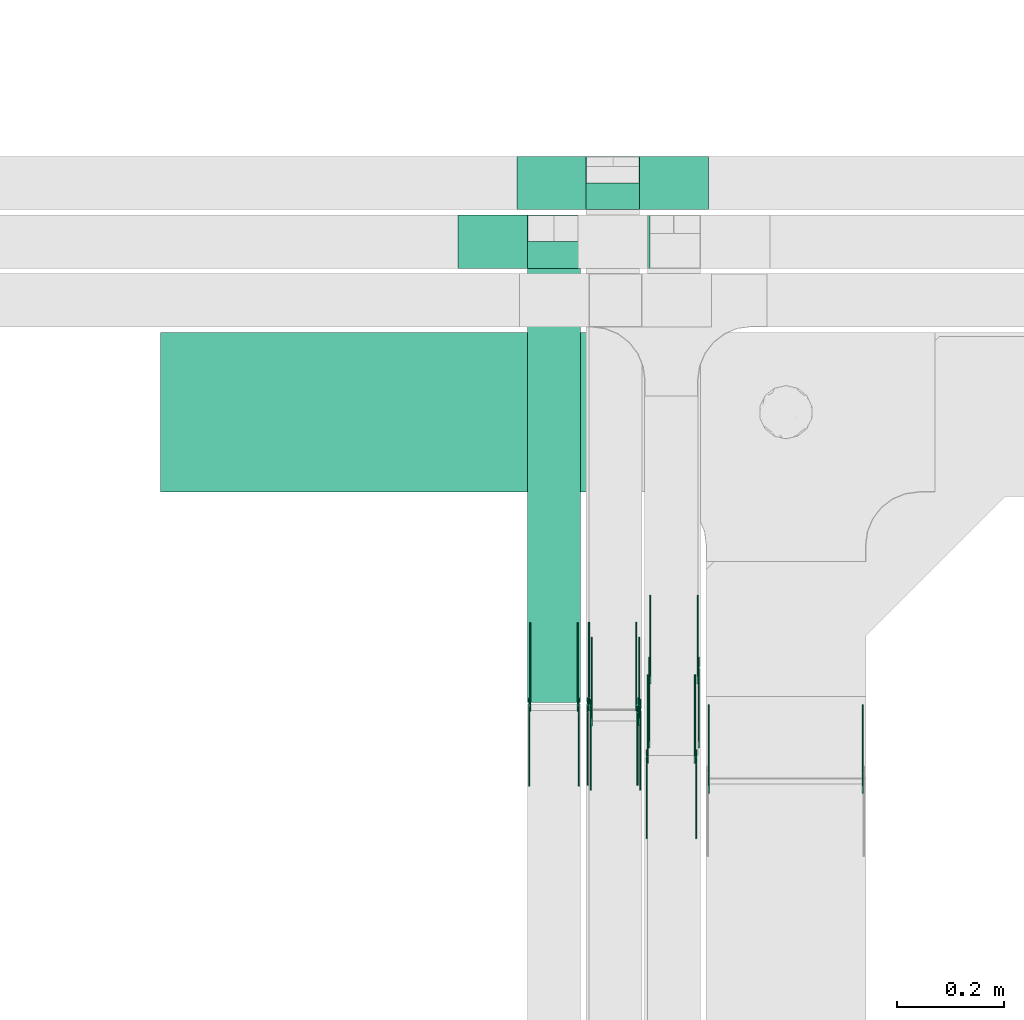
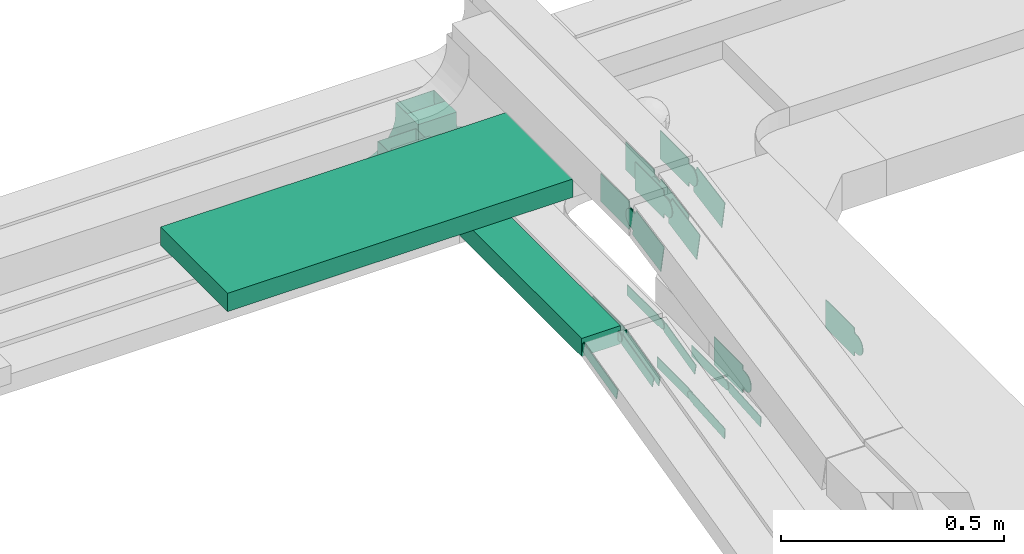
# One storey, part 9 of 33: 24 flow fittings, 2 flow segments.
"""IFC2X3 building model written with IfcOpenShell, lengths in millimetres."""

import ifcopenshell
import ifcopenshell.guid

model = None  # the IFC model being written
_history = None  # IfcOwnerHistory: only IFC2X3 demands one
_inside = {}  # id of a spatial element -> (the spatial element, [elements in it])
_under = {}  # id of a project, library or spatial element -> (it, [spatial elements below it])
_declared = {}  # id of a project -> (the project, [libraries it declares])
_typed = {}  # id of a type object -> (the type object, [elements of that type])
_made_of = {}  # id of a material, layer set ... -> (it, [elements and type objects made of it])


def new_model(schema):
    """Start an empty IFC model of exactly this schema.

    Asked for "IFC4X3", IfcOpenShell would pick the latest addendum, in which some entities
    have other attributes; the version numbers below select the first issue.
    IFC2X3 requires an IfcOwnerHistory on every rooted entity: one is made here for all.
    """
    global model, _history
    if schema == "IFC4X3":
        model = ifcopenshell.file(schema_version=(4, 3, 0, 0))
    else:
        model = ifcopenshell.file(schema=schema)
    _inside.clear()
    _under.clear()
    _declared.clear()
    _typed.clear()
    _made_of.clear()
    _history = None
    if model.schema == "IFC2X3":
        org = make("IfcOrganization", Name="unknown")
        user = make(
            "IfcPersonAndOrganization",
            ThePerson=make("IfcPerson", FamilyName="unknown"),
            TheOrganization=org,
        )
        app = make(
            "IfcApplication",
            ApplicationDeveloper=org,
            Version="unknown",
            ApplicationFullName="unknown",
            ApplicationIdentifier="unknown",
        )
        _history = make(
            "IfcOwnerHistory",
            OwningUser=user,
            OwningApplication=app,
            ChangeAction="ADDED",
            CreationDate=0,
        )
    return model


def make(cls, **values):
    """One entity of the class cls with the attributes given. An attribute that is None is left unset."""
    return model.create_entity(
        cls, **{name: value for name, value in values.items() if value is not None}
    )


def entity(cls, *values):
    """Any entity or typed value of the class cls, its attributes in the order of the schema. None: left unset."""
    e = model.create_entity(cls)
    for i, value in enumerate(values):
        if value is not None:
            e[i] = value
    return e


def rooted(cls, **values):
    """An entity with a GlobalId (a new one), such as an element, a storey or a relation."""
    return make(cls, GlobalId=ifcopenshell.guid.new(), OwnerHistory=_history, **values)


def si_unit(unit_type, name, prefix=None):
    """IfcSIUnit, for example si_unit("LENGTHUNIT", "METRE", prefix="MILLI")."""
    return make("IfcSIUnit", UnitType=unit_type, Prefix=prefix, Name=name)


def converted_unit(unit_type, name, factor, base, dimensions=None, offset=None):
    """IfcConversionBasedUnit, such as the inch: factor (a typed value) times the base unit."""
    return make(
        "IfcConversionBasedUnit"
        if offset is None
        else "IfcConversionBasedUnitWithOffset",
        ConversionOffset=offset,
        Dimensions=None
        if dimensions is None
        else entity("IfcDimensionalExponents", *dimensions),
        UnitType=unit_type,
        Name=name,
        ConversionFactor=make(
            "IfcMeasureWithUnit", ValueComponent=factor, UnitComponent=base
        ),
    )


def derived_unit(unit_type, elements):
    """IfcDerivedUnit: a product of units, each with its exponent."""
    return make(
        "IfcDerivedUnit",
        Elements=[
            make("IfcDerivedUnitElement", Unit=unit, Exponent=power)
            for unit, power in elements
        ],
        UnitType=unit_type,
    )


def assignment(units):
    """IfcUnitAssignment: the units of a project."""
    return None if units is None else make("IfcUnitAssignment", Units=units)


def point(xyz):
    """IfcCartesianPoint."""
    return None if xyz is None else make("IfcCartesianPoint", Coordinates=xyz)


def direction(xyz):
    """IfcDirection."""
    return None if xyz is None else make("IfcDirection", DirectionRatios=xyz)


def frame(location, z_axis=None, x_axis=None):
    """IfcAxis2Placement3D, a coordinate frame: its origin and axes. An axis left out is left unset."""
    return make(
        "IfcAxis2Placement3D",
        Location=point(location),
        Axis=direction(z_axis),
        RefDirection=direction(x_axis),
    )


def frame_2d(location, x_axis=None):
    """IfcAxis2Placement2D, a coordinate frame in the plane: its origin and x axis."""
    return make(
        "IfcAxis2Placement2D", Location=point(location), RefDirection=direction(x_axis)
    )


def origin():
    """The frame at (0, 0, 0) with its axes left unset."""
    return frame((0.0, 0.0, 0.0))


def origin_2d_with_axis():
    """The frame at (0, 0) in the plane with the x axis (1, 0) written out."""
    return frame_2d((0.0, 0.0), x_axis=(1.0, 0.0))


def place(relative_to, where):
    """IfcLocalPlacement: puts the frame where relative to a parent placement (None: the world)."""
    return make(
        "IfcLocalPlacement", PlacementRelTo=relative_to, RelativePlacement=where
    )


def context(
    kind, dimensions, precision=None, world=None, true_north=None, identifier=None
):
    """IfcGeometricRepresentationContext, for example the 3D "Model" context."""
    return make(
        "IfcGeometricRepresentationContext",
        ContextIdentifier=identifier,
        ContextType=kind,
        CoordinateSpaceDimension=dimensions,
        Precision=precision,
        WorldCoordinateSystem=world,
        TrueNorth=true_north,
    )


def subcontext(parent, identifier, kind, view, scale=None):
    """IfcGeometricRepresentationSubContext, for example "Body" below "Model"."""
    return make(
        "IfcGeometricRepresentationSubContext",
        ContextIdentifier=identifier,
        ContextType=kind,
        ParentContext=parent,
        TargetScale=scale,
        TargetView=view,
    )


def project(units=None, contexts=None):
    """IfcProject with its units and contexts."""
    return rooted(
        "IfcProject",
        Name="project",
        RepresentationContexts=contexts,
        UnitsInContext=assignment(units),
    )


def spatial(cls, under=None, at=None, **own):
    """A site, building, storey or space (cls), placed at a placement, below another one or the project."""
    s = rooted(cls, ObjectPlacement=at, **own)
    if under is not None:
        _under.setdefault(under.id(), (under, []))[1].append(s)
    return s


def polyline(points):
    """IfcPolyline through the points."""
    return make("IfcPolyline", Points=[point(p) for p in points])


def circle_curve(where, radius):
    """IfcCircle in the frame where."""
    return make("IfcCircle", Position=where, Radius=radius)


def parameter(value):
    """IfcParameterValue: where a trimmed curve begins or ends, as a parameter of its basis curve."""
    return model.create_entity("IfcParameterValue", value)


def trimmed(basis, trim1, trim2, sense, master):
    """IfcTrimmedCurve: the piece of a basis curve between two trims."""
    return make(
        "IfcTrimmedCurve",
        BasisCurve=basis,
        Trim1=trim1,
        Trim2=trim2,
        SenseAgreement=sense,
        MasterRepresentation=master,
    )


def segment(curve, same_sense, transition):
    """IfcCompositeCurveSegment."""
    return make(
        "IfcCompositeCurveSegment",
        Transition=transition,
        SameSense=same_sense,
        ParentCurve=curve,
    )


def composite_curve(segments, self_intersect=None):
    """IfcCompositeCurve: segments joined end to end."""
    return make("IfcCompositeCurve", Segments=segments, SelfIntersect=self_intersect)


def profile(cls, at=None, kind="AREA", **sizes):
    """A parametric profile (cls). Its sizes go by their IFC names, for example OverallWidth=200.0."""
    return make(cls, ProfileType=kind, Position=at, **sizes)


def rectangle(**sizes):
    """IfcRectangleProfileDef."""
    return profile("IfcRectangleProfileDef", **sizes)


def outline(outer, holes=None, kind="AREA"):
    """IfcArbitraryClosedProfileDef: a profile drawn as a closed curve; with holes, ...WithVoids."""
    if holes is None:
        return make("IfcArbitraryClosedProfileDef", ProfileType=kind, OuterCurve=outer)
    return make(
        "IfcArbitraryProfileDefWithVoids",
        ProfileType=kind,
        OuterCurve=outer,
        InnerCurves=holes,
    )


def extrude(swept, where, along, depth):
    """IfcExtrudedAreaSolid: the profile swept, set in the frame where, extruded along a direction by depth."""
    return make(
        "IfcExtrudedAreaSolid",
        SweptArea=swept,
        Position=where,
        ExtrudedDirection=direction(along),
        Depth=depth,
    )


def shape(context_of_items, identifier, shape_type, items):
    """IfcShapeRepresentation: the items that make up one representation, for example the "Body"."""
    return make(
        "IfcShapeRepresentation",
        ContextOfItems=context_of_items,
        RepresentationIdentifier=identifier,
        RepresentationType=shape_type,
        Items=items,
    )


def source(mapping_origin, context_of_items, identifier, shape_type, items):
    """IfcRepresentationMap: a shape defined once, which mapped items show again and again."""
    return make(
        "IfcRepresentationMap",
        MappingOrigin=mapping_origin,
        MappedRepresentation=shape(context_of_items, identifier, shape_type, items),
    )


def transform(
    local_origin,
    x_axis=None,
    y_axis=None,
    z_axis=None,
    scale=None,
    scale2=None,
    scale3=None,
    uniform=True,
):
    """IfcCartesianTransformationOperator3D, or its non-uniform kind. x_axis, y_axis, z_axis: its Axis1, 2, 3."""
    if uniform:
        return make(
            "IfcCartesianTransformationOperator3D",
            Axis1=direction(x_axis),
            Axis2=direction(y_axis),
            LocalOrigin=point(local_origin),
            Scale=scale,
            Axis3=direction(z_axis),
        )
    return make(
        "IfcCartesianTransformationOperator3DnonUniform",
        Axis1=direction(x_axis),
        Axis2=direction(y_axis),
        LocalOrigin=point(local_origin),
        Scale=scale,
        Axis3=direction(z_axis),
        Scale2=scale2,
        Scale3=scale3,
    )


def mapped(mapping_source, mapping_target):
    """IfcMappedItem: shows the shape of a source again, moved by a transform."""
    return make(
        "IfcMappedItem", MappingSource=mapping_source, MappingTarget=mapping_target
    )


def material(Name=None, Category=None):
    """IfcMaterial."""
    return make("IfcMaterial", Name=Name, Category=Category)


def material_list(materials):
    """IfcMaterialList."""
    return make("IfcMaterialList", Materials=materials)


def made_of(thing, what):
    """Note that an element or type object is made of a material, layer set ...; save() writes the relation."""
    if what is not None:
        _made_of.setdefault(what.id(), (what, []))[1].append(thing)
    return thing


def type_object(cls, material=None, **own):
    """A type object (cls), such as IfcWallType, which elements share."""
    return made_of(rooted(cls, **own), material)


def type_shapes(of_type, sources):
    """Give a type object the sources (RepresentationMaps) that its elements show as mapped items."""
    of_type.RepresentationMaps = sources


def element(
    cls,
    number,
    at=None,
    inside=None,
    cuts=None,
    type_object=None,
    material=None,
    context=None,
    identifier="Body",
    shape_type=None,
    held_by="IfcProductDefinitionShape",
    body=None,
    shapes=None,
    **own,
):
    """One element of the class cls, such as IfcWall. Its Tag is "e" and its number.

    at: its placement. inside: the storey or other place that contains it. cuts: it is an
    opening in that element (IfcRelVoidsElement). A single representation is given by context,
    identifier, shape_type and body (its items); several are given by shapes. held_by: the class
    of the entity that holds the representations. save() writes the other relations.
    """
    e = rooted(cls, Tag="e%d" % number, ObjectPlacement=at, **own)
    if body is not None:
        shapes = [shape(context, identifier, shape_type, body)]
    if shapes is not None:
        e.Representation = make(held_by, Representations=shapes)
    if inside is not None:
        _inside.setdefault(inside.id(), (inside, []))[1].append(e)
    if cuts is not None:
        rooted(
            "IfcRelVoidsElement", RelatingBuildingElement=cuts, RelatedOpeningElement=e
        )
    if type_object is not None:
        _typed.setdefault(type_object.id(), (type_object, []))[1].append(e)
    return made_of(e, material)


def aggregate(whole, parts):
    """IfcRelAggregates: a whole, such as a stair, and the parts it consists of."""
    return rooted("IfcRelAggregates", RelatingObject=whole, RelatedObjects=parts)


def save(model, path):
    """Write the relations noted so far, then the file.

    IfcRelAggregates (storeys below a building ...), IfcRelContainedInSpatialStructure (elements
    in a storey), IfcRelDefinesByType, IfcRelAssociatesMaterial and IfcRelDeclares: one each for
    every whole, place, type object, material and project.
    """
    for whole, parts in _under.values():
        aggregate(whole, parts)
    for where, things in _inside.values():
        rooted(
            "IfcRelContainedInSpatialStructure",
            RelatedElements=things,
            RelatingStructure=where,
        )
    for kind, things in _typed.values():
        rooted("IfcRelDefinesByType", RelatedObjects=things, RelatingType=kind)
    for what, things in _made_of.values():
        rooted("IfcRelAssociatesMaterial", RelatedObjects=things, RelatingMaterial=what)
    for by, libraries in _declared.values():
        rooted("IfcRelDeclares", RelatingContext=by, RelatedDefinitions=libraries)
    model.write(path)


model = new_model("IFC2X3")

# Units and contexts
model_context = context("Model", 3, precision=0.01, world=origin(), true_north=direction((6.12303176911189e-17, 1.0)))
body_context = subcontext(model_context, "Body", "Model", "MODEL_VIEW")
ifc_project = project(units=[si_unit("LENGTHUNIT", "METRE", prefix="MILLI"), si_unit("AREAUNIT", "SQUARE_METRE"), si_unit("VOLUMEUNIT", "CUBIC_METRE"), converted_unit("PLANEANGLEUNIT", "DEGREE", entity("IfcRatioMeasure", 0.0174532925199433), si_unit("PLANEANGLEUNIT", "RADIAN"), dimensions=[0, 0, 0, 0, 0, 0, 0]), si_unit("MASSUNIT", "GRAM", prefix="KILO"), derived_unit("MASSDENSITYUNIT", [(si_unit("MASSUNIT", "GRAM", prefix="KILO"), 1), (si_unit("LENGTHUNIT", "METRE"), -3)]), derived_unit("MOMENTOFINERTIAUNIT", [(si_unit("LENGTHUNIT", "METRE"), 4)]), si_unit("TIMEUNIT", "SECOND"), si_unit("FREQUENCYUNIT", "HERTZ"), si_unit("THERMODYNAMICTEMPERATUREUNIT", "DEGREE_CELSIUS"), derived_unit("THERMALTRANSMITTANCEUNIT", [(si_unit("MASSUNIT", "GRAM", prefix="KILO"), 1), (si_unit("THERMODYNAMICTEMPERATUREUNIT", "KELVIN"), -1), (si_unit("TIMEUNIT", "SECOND"), -3)]), derived_unit("VOLUMETRICFLOWRATEUNIT", [(si_unit("LENGTHUNIT", "METRE"), 3), (si_unit("TIMEUNIT", "SECOND"), -1)]), derived_unit("MASSFLOWRATEUNIT", [(si_unit("MASSUNIT", "GRAM", prefix="KILO"), 1), (si_unit("TIMEUNIT", "SECOND"), -1)]), derived_unit("ROTATIONALFREQUENCYUNIT", [(si_unit("TIMEUNIT", "SECOND"), -1)]), si_unit("ELECTRICCURRENTUNIT", "AMPERE"), si_unit("ELECTRICVOLTAGEUNIT", "VOLT"), si_unit("POWERUNIT", "WATT"), si_unit("FORCEUNIT", "NEWTON", prefix="KILO"), si_unit("ILLUMINANCEUNIT", "LUX"), si_unit("LUMINOUSFLUXUNIT", "LUMEN"), si_unit("LUMINOUSINTENSITYUNIT", "CANDELA"), derived_unit("USERDEFINED", [(si_unit("MASSUNIT", "GRAM", prefix="KILO"), -1), (si_unit("LENGTHUNIT", "METRE"), -2), (si_unit("TIMEUNIT", "SECOND"), 3), (si_unit("LUMINOUSFLUXUNIT", "LUMEN"), 1)]), derived_unit("LINEARVELOCITYUNIT", [(si_unit("LENGTHUNIT", "METRE"), 1), (si_unit("TIMEUNIT", "SECOND"), -1)]), si_unit("PRESSUREUNIT", "PASCAL"), derived_unit("USERDEFINED", [(si_unit("LENGTHUNIT", "METRE"), -2), (si_unit("MASSUNIT", "GRAM", prefix="KILO"), 1), (si_unit("TIMEUNIT", "SECOND"), -2)]), derived_unit("LINEARFORCEUNIT", [(si_unit("MASSUNIT", "GRAM", prefix="KILO"), 1), (si_unit("LENGTHUNIT", "METRE"), 1), (si_unit("TIMEUNIT", "SECOND"), -2), (si_unit("LENGTHUNIT", "METRE"), -1)]), derived_unit("PLANARFORCEUNIT", [(si_unit("MASSUNIT", "GRAM", prefix="KILO"), 1), (si_unit("LENGTHUNIT", "METRE"), 1), (si_unit("TIMEUNIT", "SECOND"), -2), (si_unit("LENGTHUNIT", "METRE"), -2)])], contexts=[model_context])

# Site, building, storey
site_placement = place(None, frame((0.0, -0.00077364408347762, 0.0)))
site = spatial("IfcSite", under=ifc_project, at=site_placement, CompositionType="ELEMENT")
building_placement = place(site_placement, origin())
building = spatial("IfcBuilding", under=site, at=building_placement, CompositionType="ELEMENT")
storey_placement = place(building_placement, frame((0.0, 0.0, 8100.0)))
storey = spatial("IfcBuildingStorey", under=building, at=storey_placement, CompositionType="ELEMENT", Elevation=8100.0)

# Flow segments
cable_carrier_segment_type = type_object("IfcCableCarrierSegmentType", PredefinedType="CABLETRAYSEGMENT")
flow_segment_1_placement = place(storey_placement, frame((17222.5, 14182.2782357464, 2840.01712441882)))
element("IfcFlowSegment", 1, at=flow_segment_1_placement, inside=storey, type_object=cable_carrier_segment_type, context=body_context, shape_type="SweptSolid", body=[
    extrude(rectangle(XDim=893.552364207236, YDim=300.000000000001, at=origin_2d_with_axis()), frame((446.776182103618, 150.0, 0.0), z_axis=(0.0, 0.0, 1.0), x_axis=(-1.0, 0.0, 0.0)), (0.0, 0.0, 1.0), 50.0000000000016),
])
flow_segment_2_placement = place(storey_placement, frame((17911.0123642174, 13787.7761473491, 2715.0)))
element("IfcFlowSegment", 2, at=flow_segment_2_placement, inside=storey, type_object=cable_carrier_segment_type, context=body_context, shape_type="SweptSolid", body=[
    extrude(rectangle(XDim=855.502088397182, YDim=99.9999999999989, at=frame_2d((1.10844666778576e-12, -1.08357767203415e-12), x_axis=(1.0, 0.0))), frame((50.0, 427.751044198592, 0.0), z_axis=(0.0, 0.0, 1.0), x_axis=(0.0, 1.0, 0.0)), (0.0, 0.0, 1.0), 50.0000000000016),
])

# Flow fittings
ifc_material_1 = material(Name="G")
cable_carrier_fitting_type_1 = type_object("IfcCableCarrierFittingType", PredefinedType="NOTDEFINED", material=ifc_material_1)
shared_shape_1 = source(origin(), body_context, "Body", "SweptSolid", [
    extrude(outline(composite_curve([segment(trimmed(circle_curve(frame_2d((-44.5901162790698, 0.0), x_axis=(1.0, 0.0)), 12.5), [parameter(90.0000000000007)], [parameter(270.0)], True, "PARAMETER"), True, "CONTINUOUS"), segment(polyline([(-44.5901162790697, -12.5), (-33.0901162790698, -12.5)]), True, "CONTINUOUS"), segment(polyline([(-33.0901162790698, -12.5), (-31.2296511627907, -14.5)]), True, "CONTINUOUS"), segment(polyline([(-31.2296511627907, -14.5), (108.90988372093, -14.5)]), True, "CONTINUOUS"), segment(polyline([(108.90988372093, -14.5), (108.90988372093, 14.5)]), True, "CONTINUOUS"), segment(polyline([(108.90988372093, 14.5), (-31.2296511627907, 14.5)]), True, "CONTINUOUS"), segment(polyline([(-31.2296511627907, 14.5), (-33.0901162790698, 12.5)]), True, "CONTINUOUS"), segment(polyline([(-33.0901162790698, 12.5), (-44.5901162790699, 12.5)]), True, "CONTINUOUS")], self_intersect=False)), frame((44.5901162790698, 0.0, 0.0), z_axis=(0.0, 0.0, -1.0), x_axis=(1.0, 0.0, 0.0)), (0.0, 0.0, -1.0), 2.0),
])
type_shapes(cable_carrier_fitting_type_1, [shared_shape_1])
for number, where, z_axis, x_axis in (
    (3, (18226.4723642276, 13686.0975961356, 2590.34290576128), (1.0, 0.0, 0.0), (0.0, -0.99765699277583, -0.068414360813261)),
    (4, (18006.4723642276, 13783.2782357461, 2740.0), (1.0, 0.0, 0.0), (0.0, -0.971320023080273, -0.237775971795593)),
    (5, (18116.4723642276, 13784.325085641, 2735.72359538163), (1.0, 0.0, 0.0), (0.0, -0.971320023080273, -0.237775971795593)),
):
    element("IfcFlowFitting", number, at=place(storey_placement, frame(where, z_axis=z_axis, x_axis=x_axis)), inside=storey, type_object=cable_carrier_fitting_type_1, material=ifc_material_1, context=body_context, shape_type="MappedRepresentation", body=[
        mapped(shared_shape_1, transform((0.0, 0.0, 0.0), scale=1.0)),
    ])
cable_carrier_fitting_type_2 = type_object("IfcCableCarrierFittingType", PredefinedType="NOTDEFINED", material=ifc_material_1)
shared_shape_2 = source(origin(), body_context, "Body", "SweptSolid", [
    extrude(outline(composite_curve([segment(trimmed(circle_curve(frame_2d((-44.5901162790697, 0.0), x_axis=(1.0, 0.0)), 12.5), [parameter(90.0000000000007)], [parameter(270.0)], True, "PARAMETER"), True, "CONTINUOUS"), segment(polyline([(-44.5901162790697, -12.5), (-33.0901162790697, -12.5)]), True, "CONTINUOUS"), segment(polyline([(-33.0901162790697, -12.5), (-31.2296511627907, -14.5)]), True, "CONTINUOUS"), segment(polyline([(-31.2296511627907, -14.5), (108.90988372093, -14.5)]), True, "CONTINUOUS"), segment(polyline([(108.90988372093, -14.5), (108.90988372093, 14.5)]), True, "CONTINUOUS"), segment(polyline([(108.90988372093, 14.5), (-31.2296511627907, 14.5)]), True, "CONTINUOUS"), segment(polyline([(-31.2296511627907, 14.5), (-33.0901162790698, 12.5)]), True, "CONTINUOUS"), segment(polyline([(-33.0901162790698, 12.5), (-44.5901162790699, 12.5)]), True, "CONTINUOUS")], self_intersect=False)), frame((44.5901162790697, 0.0, 0.0)), (0.0, 0.0, 1.0), 2.0),
])
type_shapes(cable_carrier_fitting_type_2, [shared_shape_2])
for number, where, z_axis, x_axis in (
    (6, (18135.5523642072, 13686.0975961356, 2590.34290576128), (-1.0, 0.0, 0.0), (0.0, -0.99765699277583, -0.068414360813261)),
    (7, (17915.5523642073, 13783.2782357461, 2740.0), (-1.0, 0.0, 0.0), (0.0, -0.971320023080273, -0.237775971795593)),
    (8, (18025.5523642072, 13784.325085641, 2735.72359538163), (-1.0, 0.0, 0.0), (0.0, -0.971320023080273, -0.237775971795593)),
):
    element("IfcFlowFitting", number, at=place(storey_placement, frame(where, z_axis=z_axis, x_axis=x_axis)), inside=storey, type_object=cable_carrier_fitting_type_2, material=ifc_material_1, context=body_context, shape_type="MappedRepresentation", body=[
        mapped(shared_shape_2, transform((0.0, 0.0, 0.0), scale=1.0)),
    ])
cable_carrier_fitting_type_3 = type_object("IfcCableCarrierFittingType", PredefinedType="NOTDEFINED", material=ifc_material_1)
shared_shape_3 = source(origin(), body_context, "Body", "SweptSolid", [
    extrude(outline(composite_curve([segment(trimmed(circle_curve(frame_2d((-44.5901162790698, 0.0), x_axis=(1.0, 0.0)), 12.5), [parameter(90.0000000000007)], [parameter(270.0)], True, "PARAMETER"), True, "CONTINUOUS"), segment(polyline([(-44.5901162790697, -12.5), (-33.0901162790698, -12.5)]), True, "CONTINUOUS"), segment(polyline([(-33.0901162790698, -12.5), (-31.2296511627907, -14.5)]), True, "CONTINUOUS"), segment(polyline([(-31.2296511627907, -14.5), (108.90988372093, -14.5)]), True, "CONTINUOUS"), segment(polyline([(108.90988372093, -14.5), (108.90988372093, 14.5)]), True, "CONTINUOUS"), segment(polyline([(108.90988372093, 14.5), (-31.2296511627907, 14.5)]), True, "CONTINUOUS"), segment(polyline([(-31.2296511627907, 14.5), (-33.0901162790698, 12.5)]), True, "CONTINUOUS"), segment(polyline([(-33.0901162790698, 12.5), (-44.5901162790699, 12.5)]), True, "CONTINUOUS")], self_intersect=False)), frame((44.5901162790698, 0.0, 0.0), z_axis=(0.0, 0.0, -1.0), x_axis=(1.0, 0.0, 0.0)), (0.0, 0.0, -1.0), 2.0),
])
type_shapes(cable_carrier_fitting_type_3, [shared_shape_3])
for number, where, z_axis, x_axis in (
    (9, (18137.5523642072, 13686.0975961356, 2590.34290576128), (-1.0, 0.0, 0.0), (0.0, 1.0, 0.0)),
    (10, (17917.5523642073, 13783.2782357461, 2740.0), (-1.0, 0.0, 0.0), (0.0, 1.0, 0.0)),
    (11, (18027.5523642072, 13784.325085641, 2735.72359538163), (-1.0, 0.0, 0.0), (0.0, 1.0, 0.0)),
):
    element("IfcFlowFitting", number, at=place(storey_placement, frame(where, z_axis=z_axis, x_axis=x_axis)), inside=storey, type_object=cable_carrier_fitting_type_3, material=ifc_material_1, context=body_context, shape_type="MappedRepresentation", body=[
        mapped(shared_shape_3, transform((0.0, 0.0, 0.0), scale=1.0)),
    ])
cable_carrier_fitting_type_4 = type_object("IfcCableCarrierFittingType", PredefinedType="NOTDEFINED", material=ifc_material_1)
shared_shape_4 = source(origin(), body_context, "Body", "SweptSolid", [
    extrude(outline(composite_curve([segment(trimmed(circle_curve(frame_2d((-44.5901162790697, 0.0), x_axis=(1.0, 0.0)), 12.5), [parameter(90.0000000000007)], [parameter(270.0)], True, "PARAMETER"), True, "CONTINUOUS"), segment(polyline([(-44.5901162790697, -12.5), (-33.0901162790697, -12.5)]), True, "CONTINUOUS"), segment(polyline([(-33.0901162790697, -12.5), (-31.2296511627907, -14.5)]), True, "CONTINUOUS"), segment(polyline([(-31.2296511627907, -14.5), (108.90988372093, -14.5)]), True, "CONTINUOUS"), segment(polyline([(108.90988372093, -14.5), (108.90988372093, 14.5)]), True, "CONTINUOUS"), segment(polyline([(108.90988372093, 14.5), (-31.2296511627907, 14.5)]), True, "CONTINUOUS"), segment(polyline([(-31.2296511627907, 14.5), (-33.0901162790698, 12.5)]), True, "CONTINUOUS"), segment(polyline([(-33.0901162790698, 12.5), (-44.5901162790699, 12.5)]), True, "CONTINUOUS")], self_intersect=False)), frame((44.5901162790697, 0.0, 0.0)), (0.0, 0.0, 1.0), 2.0),
])
type_shapes(cable_carrier_fitting_type_4, [shared_shape_4])
for number, where, z_axis, x_axis in (
    (12, (18224.4723642276, 13686.0975961356, 2590.34290576127), (1.0, 0.0, 0.0), (0.0, 1.0, 0.0)),
    (13, (18004.4723642276, 13783.2782357461, 2740.0), (1.0, 0.0, 0.0), (0.0, 1.0, 0.0)),
    (14, (18114.4723642275, 13784.325085641, 2735.72359538163), (1.0, 0.0, 0.0), (0.0, 1.0, 0.0)),
):
    element("IfcFlowFitting", number, at=place(storey_placement, frame(where, z_axis=z_axis, x_axis=x_axis)), inside=storey, type_object=cable_carrier_fitting_type_4, material=ifc_material_1, context=body_context, shape_type="MappedRepresentation", body=[
        mapped(shared_shape_4, transform((0.0, 0.0, 0.0), scale=1.0)),
    ])
cable_carrier_fitting_type_5 = type_object("IfcCableCarrierFittingType", PredefinedType="NOTDEFINED", material=ifc_material_1)
shared_shape_5 = source(origin(), body_context, "Body", "SweptSolid", [
    extrude(outline(composite_curve([segment(trimmed(circle_curve(frame_2d((-41.4651162790697, 0.0), x_axis=(1.0, 0.0)), 25.0), [parameter(90.0000000000007)], [parameter(270.0)], True, "PARAMETER"), True, "CONTINUOUS"), segment(polyline([(-41.4651162790697, -25.0), (-29.9651162790697, -25.0)]), True, "CONTINUOUS"), segment(polyline([(-29.9651162790697, -25.0), (-28.1046511627907, -38.5)]), True, "CONTINUOUS"), segment(polyline([(-28.1046511627907, -38.5), (99.5348837209303, -38.5)]), True, "CONTINUOUS"), segment(polyline([(99.5348837209303, -38.5), (99.5348837209303, 38.5)]), True, "CONTINUOUS"), segment(polyline([(99.5348837209303, 38.5), (-28.1046511627907, 38.5)]), True, "CONTINUOUS"), segment(polyline([(-28.1046511627907, 38.5), (-29.9651162790697, 25.0)]), True, "CONTINUOUS"), segment(polyline([(-29.9651162790697, 25.0), (-41.46511627907, 25.0)]), True, "CONTINUOUS")], self_intersect=False)), frame((41.4651162790697, 0.0, 0.0), z_axis=(0.0, 0.0, -1.0), x_axis=(1.0, 0.0, 0.0)), (0.0, 0.0, -1.0), 2.0),
])
type_shapes(cable_carrier_fitting_type_5, [shared_shape_5])
for number, where, z_axis, x_axis in (
    (15, (18231.5123642174, 13847.8132795623, 3062.11789102295), (1.0, 0.0, 0.0), (0.0, -0.983372782908371, -0.181598375089224)),
    (16, (18121.5123642175, 13769.0832795576, 3062.11789102294), (1.0, 0.0, 0.0), (0.0, -0.981126269625946, -0.193368154177143)),
):
    element("IfcFlowFitting", number, at=place(storey_placement, frame(where, z_axis=z_axis, x_axis=x_axis)), inside=storey, type_object=cable_carrier_fitting_type_5, material=ifc_material_1, context=body_context, shape_type="MappedRepresentation", body=[
        mapped(shared_shape_5, transform((0.0, 0.0, 0.0), scale=1.0)),
    ])
cable_carrier_fitting_type_6 = type_object("IfcCableCarrierFittingType", PredefinedType="NOTDEFINED", material=ifc_material_1)
shared_shape_6 = source(origin(), body_context, "Body", "SweptSolid", [
    extrude(outline(composite_curve([segment(trimmed(circle_curve(frame_2d((-41.4651162790697, 0.0), x_axis=(1.0, 0.0)), 25.0), [parameter(90.0000000000007)], [parameter(270.0)], True, "PARAMETER"), True, "CONTINUOUS"), segment(polyline([(-41.4651162790697, -25.0), (-29.9651162790697, -25.0)]), True, "CONTINUOUS"), segment(polyline([(-29.9651162790697, -25.0), (-28.1046511627907, -38.5)]), True, "CONTINUOUS"), segment(polyline([(-28.1046511627907, -38.5), (99.5348837209303, -38.5)]), True, "CONTINUOUS"), segment(polyline([(99.5348837209303, -38.5), (99.5348837209303, 38.5)]), True, "CONTINUOUS"), segment(polyline([(99.5348837209303, 38.5), (-28.1046511627907, 38.5)]), True, "CONTINUOUS"), segment(polyline([(-28.1046511627907, 38.5), (-29.9651162790697, 25.0)]), True, "CONTINUOUS"), segment(polyline([(-29.9651162790697, 25.0), (-41.46511627907, 25.0)]), True, "CONTINUOUS")], self_intersect=False)), frame((41.4651162790697, 0.0, 0.0)), (0.0, 0.0, 1.0), 2.0),
])
type_shapes(cable_carrier_fitting_type_6, [shared_shape_6])
for number, where, z_axis, x_axis in (
    (17, (18140.5923641971, 13847.8132795623, 3062.11789102295), (-1.0, 0.0, 0.0), (0.0, -0.983372782908371, -0.181598375089224)),
    (18, (18030.5923641972, 13769.0832795576, 3062.11789102294), (-1.0, 0.0, 0.0), (0.0, -0.981126269625946, -0.193368154177143)),
):
    element("IfcFlowFitting", number, at=place(storey_placement, frame(where, z_axis=z_axis, x_axis=x_axis)), inside=storey, type_object=cable_carrier_fitting_type_6, material=ifc_material_1, context=body_context, shape_type="MappedRepresentation", body=[
        mapped(shared_shape_6, transform((0.0, 0.0, 0.0), scale=1.0)),
    ])
cable_carrier_fitting_type_7 = type_object("IfcCableCarrierFittingType", PredefinedType="NOTDEFINED", material=ifc_material_1)
shared_shape_7 = source(origin(), body_context, "Body", "SweptSolid", [
    extrude(outline(composite_curve([segment(trimmed(circle_curve(frame_2d((-41.4651162790697, 0.0), x_axis=(1.0, 0.0)), 25.0), [parameter(90.0000000000007)], [parameter(270.0)], True, "PARAMETER"), True, "CONTINUOUS"), segment(polyline([(-41.4651162790697, -25.0), (-29.9651162790697, -25.0)]), True, "CONTINUOUS"), segment(polyline([(-29.9651162790697, -25.0), (-28.1046511627907, -38.5)]), True, "CONTINUOUS"), segment(polyline([(-28.1046511627907, -38.5), (99.5348837209303, -38.5)]), True, "CONTINUOUS"), segment(polyline([(99.5348837209303, -38.5), (99.5348837209303, 38.5)]), True, "CONTINUOUS"), segment(polyline([(99.5348837209303, 38.5), (-28.1046511627907, 38.5)]), True, "CONTINUOUS"), segment(polyline([(-28.1046511627907, 38.5), (-29.9651162790697, 25.0)]), True, "CONTINUOUS"), segment(polyline([(-29.9651162790697, 25.0), (-41.46511627907, 25.0)]), True, "CONTINUOUS")], self_intersect=False)), frame((41.4651162790697, 0.0, 0.0), z_axis=(0.0, 0.0, -1.0), x_axis=(1.0, 0.0, 0.0)), (0.0, 0.0, -1.0), 2.0),
])
type_shapes(cable_carrier_fitting_type_7, [shared_shape_7])
for number, where, z_axis, x_axis in (
    (19, (18252.5923641971, 13642.501098777, 2615.0), (-1.0, 0.0, 0.0), (0.0, 1.0, 0.0)),
    (20, (18142.5923641971, 13847.8132795622, 3062.11789102294), (-1.0, 0.0, 0.0), (0.0, 1.0, 0.0)),
    (21, (18032.5923641972, 13769.0832795576, 3062.11789102294), (-1.0, 0.0, 0.0), (0.0, 1.0, 0.0)),
):
    element("IfcFlowFitting", number, at=place(storey_placement, frame(where, z_axis=z_axis, x_axis=x_axis)), inside=storey, type_object=cable_carrier_fitting_type_7, material=ifc_material_1, context=body_context, shape_type="MappedRepresentation", body=[
        mapped(shared_shape_7, transform((0.0, 0.0, 0.0), scale=1.0)),
    ])
cable_carrier_fitting_type_8 = type_object("IfcCableCarrierFittingType", PredefinedType="NOTDEFINED", material=ifc_material_1)
shared_shape_8 = source(origin(), body_context, "Body", "SweptSolid", [
    extrude(outline(composite_curve([segment(trimmed(circle_curve(frame_2d((-41.4651162790697, 0.0), x_axis=(1.0, 0.0)), 25.0), [parameter(90.0000000000007)], [parameter(270.0)], True, "PARAMETER"), True, "CONTINUOUS"), segment(polyline([(-41.4651162790697, -25.0), (-29.9651162790697, -25.0)]), True, "CONTINUOUS"), segment(polyline([(-29.9651162790697, -25.0), (-28.1046511627907, -38.5)]), True, "CONTINUOUS"), segment(polyline([(-28.1046511627907, -38.5), (99.5348837209303, -38.5)]), True, "CONTINUOUS"), segment(polyline([(99.5348837209303, -38.5), (99.5348837209303, 38.5)]), True, "CONTINUOUS"), segment(polyline([(99.5348837209303, 38.5), (-28.1046511627907, 38.5)]), True, "CONTINUOUS"), segment(polyline([(-28.1046511627907, 38.5), (-29.9651162790697, 25.0)]), True, "CONTINUOUS"), segment(polyline([(-29.9651162790697, 25.0), (-41.46511627907, 25.0)]), True, "CONTINUOUS")], self_intersect=False)), frame((41.4651162790697, 0.0, 0.0)), (0.0, 0.0, 1.0), 2.0),
])
type_shapes(cable_carrier_fitting_type_8, [shared_shape_8])
for number, where, z_axis, x_axis in (
    (22, (18539.5123642174, 13642.501098777, 2615.0), (1.0, 0.0, 0.0), (0.0, 1.0, 0.0)),
    (23, (18229.5123642174, 13847.8132795622, 3062.11789102294), (1.0, 0.0, 0.0), (0.0, 1.0, 0.0)),
    (24, (18119.5123642175, 13769.0832795576, 3062.11789102293), (1.0, 0.0, 0.0), (0.0, 1.0, 0.0)),
):
    element("IfcFlowFitting", number, at=place(storey_placement, frame(where, z_axis=z_axis, x_axis=x_axis)), inside=storey, type_object=cable_carrier_fitting_type_8, material=ifc_material_1, context=body_context, shape_type="MappedRepresentation", body=[
        mapped(shared_shape_8, transform((0.0, 0.0, 0.0), scale=1.0)),
    ])
ifc_material_2 = material()
ifc_material_list_1 = material_list([ifc_material_2, ifc_material_2, ifc_material_2, ifc_material_2, ifc_material_2])
ifc_material_list_2 = material_list([ifc_material_2, ifc_material_2, ifc_material_2, ifc_material_2, ifc_material_2])
cable_carrier_fitting_type_9 = type_object("IfcCableCarrierFittingType", Name="470_DKC_S5_TSS cover (flat)", PredefinedType="NOTDEFINED", material=ifc_material_list_2)
shared_shape_9 = source(origin(), body_context, "Body", "SweptSolid", [
    extrude(rectangle(XDim=99.9999999999999, YDim=49.9999999999991, at=frame_2d((0.0, -3.5527136788005e-15), x_axis=(1.0, 0.0))), frame((0.0, -25.0, 154.0)), (0.0, 0.0, 1.0), 0.999999999999908),
    extrude(outline(composite_curve([segment(polyline([(-72.7500000000004, -57.2500000000001), (-72.7500000000004, -58.2500000000001)]), True, "CONTINUOUS"), segment(polyline([(-72.7500000000004, -58.2500000000001), (-42.7499999999992, -58.2500000000001)]), True, "CONTINUOUS"), segment(trimmed(circle_curve(frame_2d((-42.7499999999995, 42.7500000000001), x_axis=(0.0, 1.0)), 101.0), [parameter(180.0)], [parameter(270.0)], True, "PARAMETER"), True, "CONTINUOUS"), segment(polyline([(58.2500000000007, 42.7499999999998), (58.2500000000007, 72.75)]), True, "CONTINUOUS"), segment(polyline([(58.2500000000007, 72.75), (57.2499999999994, 72.75)]), True, "CONTINUOUS"), segment(polyline([(57.2499999999994, 72.75), (57.2499999999994, 42.7500000000001)]), True, "CONTINUOUS"), segment(trimmed(circle_curve(frame_2d((-42.7500000000007, 42.7499999999999), x_axis=(0.0, 1.0)), 100.0), [parameter(180.0)], [parameter(270.0)], True, "PARAMETER"), False, "CONTINUOUS"), segment(polyline([(-42.7499999999995, -57.2500000000001), (-72.7500000000004, -57.2500000000001)]), True, "CONTINUOUS")], self_intersect=False)), frame((107.25, -50.0, 82.2500000000023), z_axis=(0.0, -1.0, 0.0), x_axis=(0.0, 0.0, -1.0)), (0.0, 0.0, -1.0), 100.0),
    extrude(outline(composite_curve([segment(polyline([(57.2499999999999, -72.7500000000004), (58.2500000000002, -72.7500000000004)]), True, "CONTINUOUS"), segment(polyline([(58.2500000000002, -72.7500000000004), (58.2500000000002, -42.7499999999995)]), True, "CONTINUOUS"), segment(trimmed(circle_curve(frame_2d((-42.75, -42.7499999999995), x_axis=(1.0, 0.0)), 101.0), [parameter(4.57999874130747e-13)], [parameter(90.0000000000007)], True, "PARAMETER"), True, "CONTINUOUS"), segment(polyline([(-42.7500000000003, 58.2500000000007), (-72.7500000000001, 58.2500000000007)]), True, "CONTINUOUS"), segment(polyline([(-72.7500000000001, 58.2500000000007), (-72.7500000000001, 57.2499999999993)]), True, "CONTINUOUS"), segment(polyline([(-72.7500000000001, 57.2499999999993), (-42.7499999999999, 57.2499999999993)]), True, "CONTINUOUS"), segment(trimmed(circle_curve(frame_2d((-42.7500000000001, -42.7500000000007), x_axis=(1.0, 0.0)), 100.0), [parameter(360.0)], [parameter(89.9999999999999)], True, "PARAMETER"), False, "CONTINUOUS"), segment(polyline([(57.2499999999999, -42.7500000000005), (57.2499999999999, -72.7500000000004)]), True, "CONTINUOUS")], self_intersect=False)), frame((-107.249999999999, -50.0, 82.2500000000023), z_axis=(0.0, 1.0, 0.0), x_axis=(1.0, 0.0, 0.0)), (0.0, 0.0, 1.0), 100.0),
    extrude(outline(composite_curve([segment(polyline([(-50.0, -97.5999999999999), (50.0, -97.5999999999999)]), True, "CONTINUOUS"), segment(polyline([(50.0, -97.5999999999999), (50.0, -67.5999999999997)]), True, "CONTINUOUS"), segment(trimmed(circle_curve(frame_2d((150.0, -67.6000000000002), x_axis=(1.0, 0.0)), 100.0), [parameter(90.0000000000003)], [parameter(180.0)], True, "PARAMETER"), False, "CONTINUOUS"), segment(polyline([(150.0, 32.3999999999998), (180.0, 32.3999999999998)]), True, "CONTINUOUS"), segment(polyline([(180.0, 32.3999999999998), (180.0, 100.400000000001)]), True, "CONTINUOUS"), segment(polyline([(180.0, 100.400000000001), (-180.0, 100.400000000001)]), True, "CONTINUOUS"), segment(polyline([(-180.0, 100.400000000001), (-180.0, 32.3999999999998)]), True, "CONTINUOUS"), segment(polyline([(-180.0, 32.3999999999998), (-150.0, 32.3999999999998)]), True, "CONTINUOUS"), segment(trimmed(circle_curve(frame_2d((-150.0, -67.6000000000002), x_axis=(1.0, 0.0)), 100.0), [parameter(1.01777749806833e-13)], [parameter(90.0000000000002)], True, "PARAMETER"), False, "CONTINUOUS"), segment(polyline([(-50.0, -67.6000000000002), (-50.0, -97.5999999999999)]), True, "CONTINUOUS")], self_intersect=False)), frame((0.0, -50.0, 57.4000000000028), z_axis=(0.0, 1.0, 0.0), x_axis=(1.0, 0.0, 0.0)), (0.0, 0.0, 1.0), 1.0),
    extrude(outline(composite_curve([segment(polyline([(-150.0, -32.3999999999998), (-180.0, -32.3999999999998)]), True, "CONTINUOUS"), segment(polyline([(-180.0, -32.3999999999998), (-180.0, -100.400000000001)]), True, "CONTINUOUS"), segment(polyline([(-180.0, -100.400000000001), (180.0, -100.400000000001)]), True, "CONTINUOUS"), segment(polyline([(180.0, -100.400000000001), (180.0, -32.3999999999998)]), True, "CONTINUOUS"), segment(polyline([(180.0, -32.3999999999998), (150.0, -32.3999999999998)]), True, "CONTINUOUS"), segment(trimmed(circle_curve(frame_2d((150.0, 67.6000000000003), x_axis=(1.0, 0.0)), 100.0), [parameter(180.0)], [parameter(270.0)], True, "PARAMETER"), False, "CONTINUOUS"), segment(polyline([(50.0, 67.5999999999998), (50.0, 97.6)]), True, "CONTINUOUS"), segment(polyline([(50.0, 97.6), (-50.0, 97.6)]), True, "CONTINUOUS"), segment(polyline([(-50.0, 97.6), (-50.0, 67.6000000000003)]), True, "CONTINUOUS"), segment(trimmed(circle_curve(frame_2d((-150.0, 67.6000000000003), x_axis=(1.0, 0.0)), 100.0), [parameter(270.0)], [parameter(360.0)], True, "PARAMETER"), False, "CONTINUOUS")], self_intersect=False)), frame((0.0, 49.0, 57.4000000000027), z_axis=(0.0, -1.0, 0.0), x_axis=(1.0, 0.0, 0.0)), (0.0, 0.0, -1.0), 1.00000000000003),
])
type_shapes(cable_carrier_fitting_type_9, [shared_shape_9])
flow_fitting_1_placement = place(storey_placement, frame((18071.0123642175, 14762.2782357464, 2595.0)))
element("IfcFlowFitting", 25, at=flow_fitting_1_placement, inside=storey, type_object=cable_carrier_fitting_type_9, material=ifc_material_list_1, Name="470_DKC_S5_cover (flat)", ObjectType="470_DKC_S5_TSS cover (flat)", context=body_context, shape_type="MappedRepresentation", body=[
    mapped(shared_shape_9, transform((0.0, 0.0, 0.0), scale=1.0)),
])
flow_fitting_2_placement = place(storey_placement, frame((17961.0123642174, 14652.2782357463, 2595.0)))
element("IfcFlowFitting", 26, at=flow_fitting_2_placement, inside=storey, type_object=cable_carrier_fitting_type_9, material=ifc_material_2, Name="470_DKC_S5_cover (flat)", ObjectType="470_DKC_S5_TSS cover (flat)", context=body_context, shape_type="MappedRepresentation", body=[
    mapped(shared_shape_9, transform((0.0, 0.0, 0.0), scale=1.0)),
])

save(model, "model.ifc")
